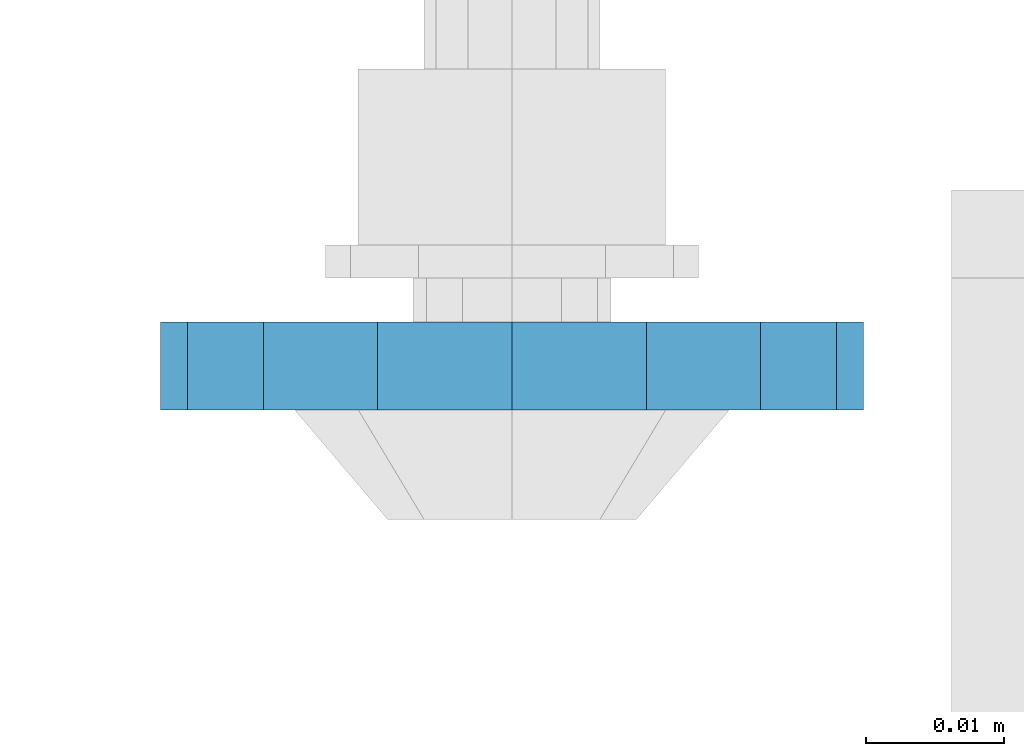
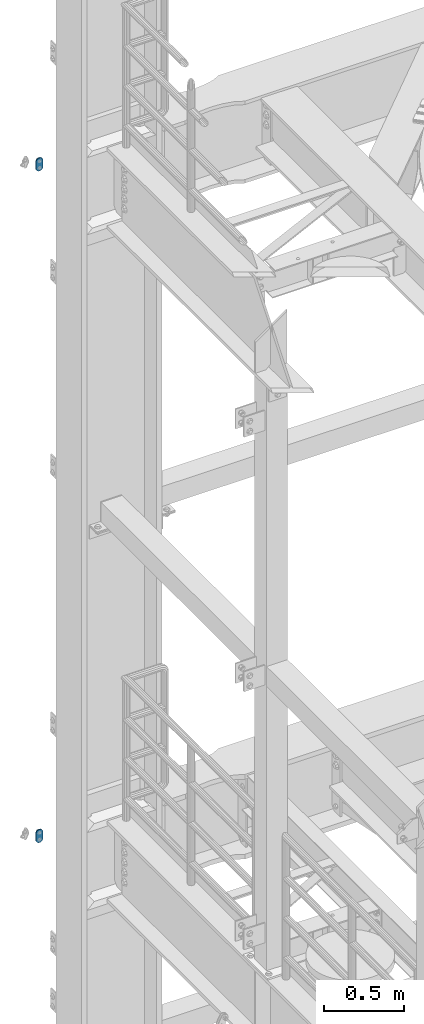
# One storey, part 1767 of 1876: 2 plates, 2 elements without a shape of their own.
"""IFC2X3 building model written with IfcOpenShell, lengths in millimetres."""

from ifc_helpers import new_model, si_unit, frame, origin_with_axes, place, context, subcontext, project, spatial, faceted_brep, material, type_object, element, aggregate, save


model = new_model("IFC2X3")

# Units and contexts
model_context = context("Model", 3, precision=1e-05, world=origin_with_axes())
body_context = subcontext(model_context, "Body", "Model", "MODEL_VIEW")
ifc_project = project(units=[si_unit("LENGTHUNIT", "METRE", prefix="MILLI"), si_unit("AREAUNIT", "SQUARE_METRE"), si_unit("VOLUMEUNIT", "CUBIC_METRE"), si_unit("MASSUNIT", "GRAM", prefix="KILO"), si_unit("TIMEUNIT", "SECOND"), si_unit("PLANEANGLEUNIT", "RADIAN"), si_unit("SOLIDANGLEUNIT", "STERADIAN"), si_unit("THERMODYNAMICTEMPERATUREUNIT", "DEGREE_CELSIUS"), si_unit("LUMINOUSINTENSITYUNIT", "LUMEN")], contexts=[model_context])

# Site, building, storey
site_placement = place(None, origin_with_axes())
site = spatial("IfcSite", under=ifc_project, at=site_placement, CompositionType="ELEMENT")
building_placement = place(site_placement, origin_with_axes())
building = spatial("IfcBuilding", under=site, at=building_placement, Name="Undefined", CompositionType="ELEMENT")
storey_placement = place(building_placement, origin_with_axes())
storey = spatial("IfcBuildingStorey", under=building, at=storey_placement, Name="Undefined", CompositionType="ELEMENT", Elevation=0.0)

# Assembly, plate
assembly_1_placement = place(storey_placement, origin_with_axes())
assembly_1 = element("IfcElementAssembly", 1, at=assembly_1_placement, inside=storey, Name="PLATE", AssemblyPlace="NOTDEFINED", PredefinedType="RIGID_FRAME")
ifc_material = material(Name="STEEL/A36")
plate_type = type_object("IfcPlateType", PredefinedType="NOTDEFINED")
plate_1_placement = place(assembly_1_placement, frame((-361.949999934441, 14008.0887929268, 7886.7), z_axis=(1.0, 0.0, 0.0), x_axis=(0.0, 0.0, -1.0)))
plate_1 = element("IfcPlate", 2, at=plate_1_placement, type_object=plate_type, material=ifc_material, Name="PLATE", context=body_context, shape_type="Brep", body=[
    faceted_brep([(-8.59611645864788e-07, -3.17499999999654, 25.3999987589127), (1.93345873884391, -3.17499999999382, 35.1201580589886), (1.93345873884391, 3.17500000000564, 35.1201580589886), (-8.59611645864788e-07, 3.17500000000382, 25.3999987589132), (7.43948648259902, -3.17499999999109, 43.3605112870105), (7.43948648259902, 3.17500000000928, 43.3605112870105), (15.6798395242777, -3.17499999998654, 48.8665393096448), (15.6798395242777, 3.17500000001382, 48.8665393096448), (25.3999987589095, -3.17499999998199, 50.7999992370592), (25.3999987589095, 3.17500000001837, 50.7999992370592), (76.1999988555108, -3.17500000000018, 50.7999992370601), (76.1999988555108, 3.17500000000018, 50.7999992370601), (85.9201578916036, -3.17500000000018, 48.8665393918844), (85.9201578916036, 3.17500000000018, 48.8665393918844), (94.1605108279182, -3.17500000000018, 43.3605115909282), (94.1605108279182, 3.17500000000018, 43.3605115909282), (99.6665386288878, -3.17500000000018, 35.1201586546208), (99.6665386288878, 3.17500000000018, 35.1201586546208), (101.599998474081, -3.17500000000018, 25.3999996185719), (101.599998474081, 3.17500000000018, 25.3999996185719), (99.6665386289205, -3.17500000000018, 15.679840582484), (99.6665386289205, 3.17500000000018, 15.679840582484), (94.1605108279837, -3.17500000000018, 7.43948764617841), (94.1605108279837, 3.17500000000018, 7.43948764617841), (85.9201578916873, -3.17500000000018, 1.93345984522131), (85.9201578916873, 3.17500000000018, 1.93345984522131), (76.1999988556054, -3.17500000000018, 4.17230694438331e-11), (76.1999988556054, 3.17500000000018, 4.17230694438331e-11), (25.399998758905, -3.17499999999018, -8.64019966684282e-12), (25.399998758905, 3.17500000001019, -8.64019966684282e-12), (15.679839921364, -3.17499999999382, 1.9334597629304), (15.679839921364, 3.17500000000655, 1.9334597629304), (7.43948709043525, -3.17499999999654, 7.43948734220839), (7.43948709043525, 3.17500000000382, 7.43948734220885), (1.93345923228208, -3.17499999999654, 15.6798399868012), (1.93345923228208, 3.17500000000291, 15.6798399868012)], [[[0, 1, 2, 3]], [[1, 4, 5, 2]], [[4, 6, 7, 5]], [[6, 8, 9, 7]], [[8, 10, 11, 9]], [[10, 12, 13, 11]], [[12, 14, 15, 13]], [[14, 16, 17, 15]], [[16, 18, 19, 17]], [[18, 20, 21, 19]], [[20, 22, 23, 21]], [[22, 24, 25, 23]], [[24, 26, 27, 25]], [[26, 28, 29, 27]], [[28, 30, 31, 29]], [[30, 32, 33, 31]], [[32, 34, 35, 33]], [[34, 0, 3, 35]], [[5, 7, 9, 11, 13, 15, 17, 19, 21, 23, 25, 27, 29, 31, 33, 35, 3, 2]], [[34, 32, 30, 28, 26, 24, 22, 20, 18, 16, 14, 12, 10, 8, 6, 4, 1, 0]]]),
])
aggregate(assembly_1, [plate_1])

assembly_2_placement = place(storey_placement, origin_with_axes())
assembly_2 = element("IfcElementAssembly", 3, at=assembly_2_placement, inside=storey, Name="PLATE", AssemblyPlace="NOTDEFINED", PredefinedType="RIGID_FRAME")
plate_2_placement = place(assembly_2_placement, frame((-361.949999934442, 14008.0887929268, 13030.2), z_axis=(1.0, 0.0, 0.0), x_axis=(0.0, 0.0, -1.0)))
plate_2 = element("IfcPlate", 4, at=plate_2_placement, type_object=plate_type, material=ifc_material, Name="PLATE", context=body_context, shape_type="Brep", body=[
    faceted_brep([(-8.59611645864788e-07, -3.17499999999654, 25.3999987589127), (1.93345873884391, -3.17499999999382, 35.1201580589886), (1.93345873884391, 3.17500000000564, 35.1201580589886), (-8.59611645864788e-07, 3.17500000000382, 25.3999987589132), (7.43948648259902, -3.17499999999109, 43.3605112870105), (7.43948648259902, 3.17500000000928, 43.3605112870105), (15.6798395242777, -3.17499999998654, 48.8665393096448), (15.6798395242777, 3.17500000001382, 48.8665393096448), (25.3999987589095, -3.17499999998199, 50.7999992370592), (25.3999987589095, 3.17500000001837, 50.7999992370592), (76.1999988555108, -3.17500000000018, 50.7999992370601), (76.1999988555108, 3.17500000000018, 50.7999992370601), (85.9201578916036, -3.17500000000018, 48.8665393918844), (85.9201578916036, 3.17500000000018, 48.8665393918844), (94.1605108279182, -3.17500000000018, 43.3605115909282), (94.1605108279182, 3.17500000000018, 43.3605115909282), (99.6665386288878, -3.17500000000018, 35.1201586546208), (99.6665386288878, 3.17500000000018, 35.1201586546208), (101.599998474081, -3.17500000000018, 25.3999996185719), (101.599998474081, 3.17500000000018, 25.3999996185719), (99.6665386289205, -3.17500000000018, 15.679840582484), (99.6665386289205, 3.17500000000018, 15.679840582484), (94.1605108279837, -3.17500000000018, 7.43948764617841), (94.1605108279837, 3.17500000000018, 7.43948764617841), (85.9201578916873, -3.17500000000018, 1.93345984522131), (85.9201578916873, 3.17500000000018, 1.93345984522131), (76.1999988556054, -3.17500000000018, 4.17230694438331e-11), (76.1999988556054, 3.17500000000018, 4.17230694438331e-11), (25.399998758905, -3.17499999999018, -8.64019966684282e-12), (25.399998758905, 3.17500000001019, -8.64019966684282e-12), (15.679839921364, -3.17499999999382, 1.9334597629304), (15.679839921364, 3.17500000000655, 1.9334597629304), (7.43948709043525, -3.17499999999654, 7.43948734220839), (7.43948709043525, 3.17500000000382, 7.43948734220885), (1.93345923228208, -3.17499999999654, 15.6798399868012), (1.93345923228208, 3.17500000000291, 15.6798399868012)], [[[0, 1, 2, 3]], [[1, 4, 5, 2]], [[4, 6, 7, 5]], [[6, 8, 9, 7]], [[8, 10, 11, 9]], [[10, 12, 13, 11]], [[12, 14, 15, 13]], [[14, 16, 17, 15]], [[16, 18, 19, 17]], [[18, 20, 21, 19]], [[20, 22, 23, 21]], [[22, 24, 25, 23]], [[24, 26, 27, 25]], [[26, 28, 29, 27]], [[28, 30, 31, 29]], [[30, 32, 33, 31]], [[32, 34, 35, 33]], [[34, 0, 3, 35]], [[5, 7, 9, 11, 13, 15, 17, 19, 21, 23, 25, 27, 29, 31, 33, 35, 3, 2]], [[34, 32, 30, 28, 26, 24, 22, 20, 18, 16, 14, 12, 10, 8, 6, 4, 1, 0]]]),
])
aggregate(assembly_2, [plate_2])

save(model, "model.ifc")
